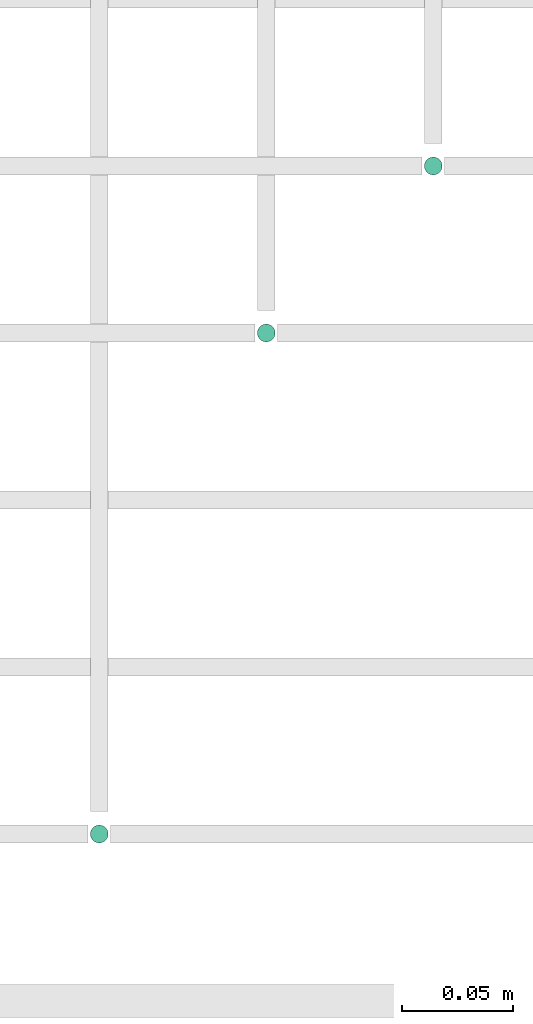
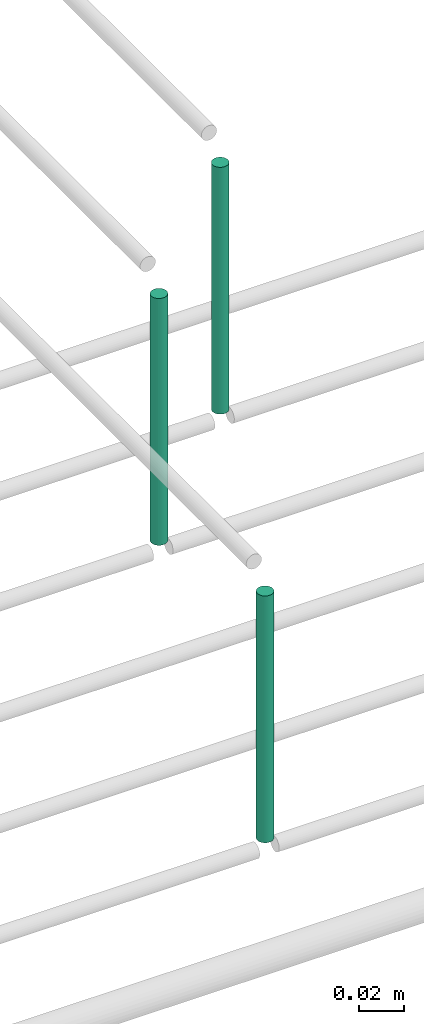
# One storey, part 42 of 89: 3 flow segments.
"""IFC2X3 building model written with IfcOpenShell, lengths in millimetres."""

from ifc_helpers import new_model, entity, si_unit, converted_unit, derived_unit, direction, frame, frame_2d, origin, origin_2d_with_axis, place, context, subcontext, project, spatial, circle, extrude, type_object, element, save


model = new_model("IFC2X3")

# Units and contexts
model_context = context("Model", 3, precision=0.01, world=origin(), true_north=direction((6.12303176911189e-17, 1.0)))
body_context = subcontext(model_context, "Body", "Model", "MODEL_VIEW")
ifc_project = project(units=[si_unit("LENGTHUNIT", "METRE", prefix="MILLI"), si_unit("AREAUNIT", "SQUARE_METRE"), si_unit("VOLUMEUNIT", "CUBIC_METRE"), converted_unit("PLANEANGLEUNIT", "DEGREE", entity("IfcRatioMeasure", 0.0174532925199433), si_unit("PLANEANGLEUNIT", "RADIAN"), dimensions=[0, 0, 0, 0, 0, 0, 0]), si_unit("MASSUNIT", "GRAM", prefix="KILO"), derived_unit("MASSDENSITYUNIT", [(si_unit("MASSUNIT", "GRAM", prefix="KILO"), 1), (si_unit("LENGTHUNIT", "METRE"), -3)]), derived_unit("MOMENTOFINERTIAUNIT", [(si_unit("LENGTHUNIT", "METRE"), 4)]), si_unit("TIMEUNIT", "SECOND"), si_unit("FREQUENCYUNIT", "HERTZ"), si_unit("THERMODYNAMICTEMPERATUREUNIT", "DEGREE_CELSIUS"), derived_unit("THERMALTRANSMITTANCEUNIT", [(si_unit("MASSUNIT", "GRAM", prefix="KILO"), 1), (si_unit("THERMODYNAMICTEMPERATUREUNIT", "KELVIN"), -1), (si_unit("TIMEUNIT", "SECOND"), -3)]), derived_unit("VOLUMETRICFLOWRATEUNIT", [(si_unit("LENGTHUNIT", "METRE"), 3), (si_unit("TIMEUNIT", "SECOND"), -1)]), derived_unit("MASSFLOWRATEUNIT", [(si_unit("MASSUNIT", "GRAM", prefix="KILO"), 1), (si_unit("TIMEUNIT", "SECOND"), -1)]), derived_unit("ROTATIONALFREQUENCYUNIT", [(si_unit("TIMEUNIT", "SECOND"), -1)]), si_unit("ELECTRICCURRENTUNIT", "AMPERE"), si_unit("ELECTRICVOLTAGEUNIT", "VOLT"), si_unit("POWERUNIT", "WATT"), si_unit("FORCEUNIT", "NEWTON", prefix="KILO"), si_unit("ILLUMINANCEUNIT", "LUX"), si_unit("LUMINOUSFLUXUNIT", "LUMEN"), si_unit("LUMINOUSINTENSITYUNIT", "CANDELA"), derived_unit("USERDEFINED", [(si_unit("MASSUNIT", "GRAM", prefix="KILO"), -1), (si_unit("LENGTHUNIT", "METRE"), -2), (si_unit("TIMEUNIT", "SECOND"), 3), (si_unit("LUMINOUSFLUXUNIT", "LUMEN"), 1)]), derived_unit("LINEARVELOCITYUNIT", [(si_unit("LENGTHUNIT", "METRE"), 1), (si_unit("TIMEUNIT", "SECOND"), -1)]), si_unit("PRESSUREUNIT", "PASCAL"), derived_unit("USERDEFINED", [(si_unit("LENGTHUNIT", "METRE"), -2), (si_unit("MASSUNIT", "GRAM", prefix="KILO"), 1), (si_unit("TIMEUNIT", "SECOND"), -2)]), derived_unit("LINEARFORCEUNIT", [(si_unit("MASSUNIT", "GRAM", prefix="KILO"), 1), (si_unit("LENGTHUNIT", "METRE"), 1), (si_unit("TIMEUNIT", "SECOND"), -2), (si_unit("LENGTHUNIT", "METRE"), -1)]), derived_unit("PLANARFORCEUNIT", [(si_unit("MASSUNIT", "GRAM", prefix="KILO"), 1), (si_unit("LENGTHUNIT", "METRE"), 1), (si_unit("TIMEUNIT", "SECOND"), -2), (si_unit("LENGTHUNIT", "METRE"), -2)])], contexts=[model_context])

# Site, building, storey
site_placement = place(None, frame((0.0, -0.00077364408347762, 0.0)))
site = spatial("IfcSite", under=ifc_project, at=site_placement, CompositionType="ELEMENT")
building_placement = place(site_placement, origin())
building = spatial("IfcBuilding", under=site, at=building_placement, CompositionType="ELEMENT")
storey_placement = place(building_placement, frame((0.0, 0.0, 24000.0)))
storey = spatial("IfcBuildingStorey", under=building, at=storey_placement, CompositionType="ELEMENT", Elevation=24000.0)

# Flow segments
pipe_segment_type = type_object("IfcPipeSegmentType", PredefinedType="NOTDEFINED")
flow_segment_1_placement = place(storey_placement, frame((47020.5982478344, 1244.35602729991, 3005.0)))
element("IfcFlowSegment", 1, at=flow_segment_1_placement, inside=storey, type_object=pipe_segment_type, context=body_context, shape_type="SweptSolid", body=[
    extrude(circle(Radius=4.0, at=frame_2d((0.0, 2.70716782324598e-13), x_axis=(1.0, 0.0))), frame((5.59527223591499, 5.59527223591607, 0.0), z_axis=(0.0, 0.0, 1.0), x_axis=(-1.0, 0.0, 0.0)), (0.0, 0.0, 1.0), 134.999999999995),
])
flow_segment_2_placement = place(storey_placement, frame((47095.5981151137, 1469.35602729994, 3005.0)))
element("IfcFlowSegment", 2, at=flow_segment_2_placement, inside=storey, type_object=pipe_segment_type, context=body_context, shape_type="SweptSolid", body=[
    extrude(circle(Radius=4.0, at=origin_2d_with_axis()), frame((5.59527223591499, 5.5952722359158, 0.0), z_axis=(0.0, 0.0, 1.0), x_axis=(-1.0, 0.0, 0.0)), (0.0, 0.0, 1.0), 134.999999999987),
])
flow_segment_3_placement = place(storey_placement, frame((47170.5981151137, 1544.35602729992, 3005.0)))
element("IfcFlowSegment", 3, at=flow_segment_3_placement, inside=storey, type_object=pipe_segment_type, context=body_context, shape_type="SweptSolid", body=[
    extrude(circle(Radius=4.0, at=origin_2d_with_axis()), frame((5.59527223591499, 5.5952722359158, 0.0), z_axis=(0.0, 0.0, 1.0), x_axis=(-1.0, 0.0, 0.0)), (0.0, 0.0, 1.0), 134.999999999995),
])

save(model, "model.ifc")
